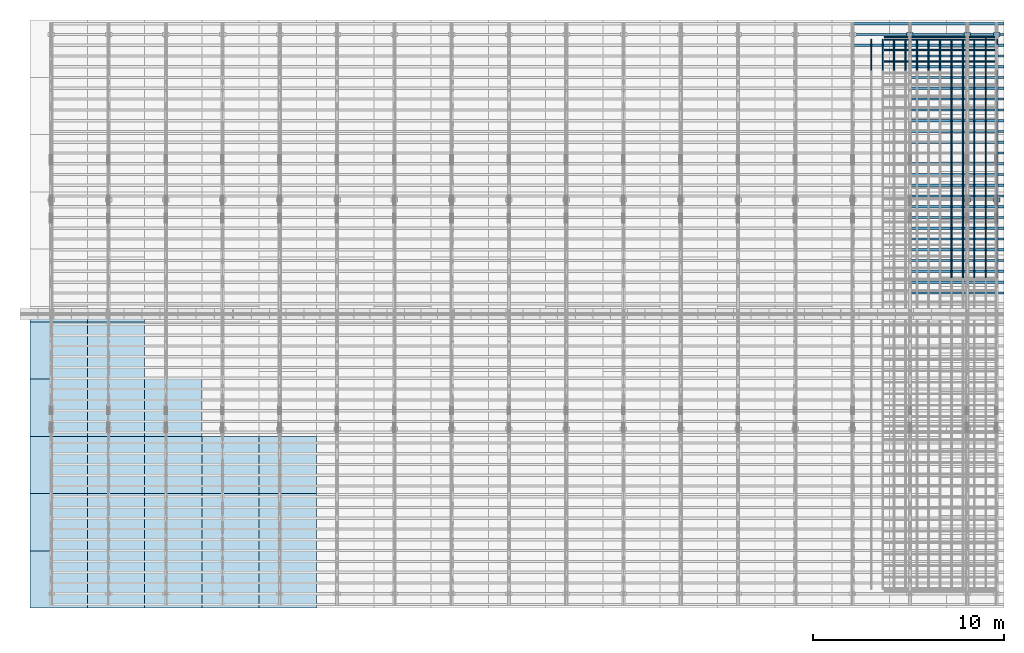
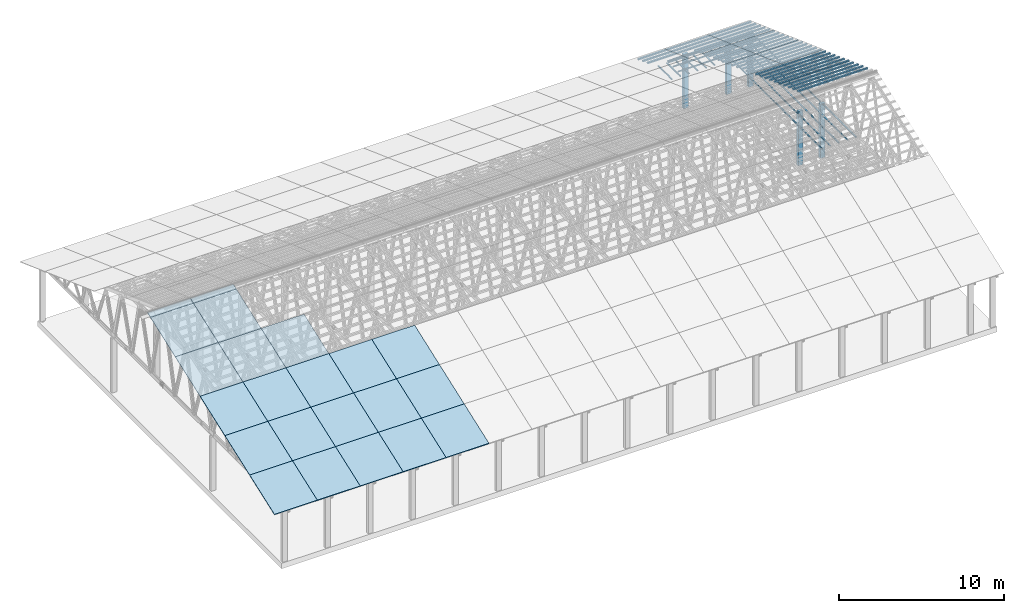
# One storey, part 5 of 189: 60 columns, 22 slabs, 22 elements without a shape of their own.
"""IFC2X3 building model written with IfcOpenShell, lengths in millimetres."""

from ifc_helpers import new_model, entity, si_unit, converted_unit, derived_unit, direction, frame, frame_2d, origin, origin_2d_with_axis, place, context, subcontext, project, spatial, rectangle, extrude, boolean, source, transform, mapped, material, layer, layer_set, type_object, type_shapes, element, aggregate, save


model = new_model("IFC2X3")

# Units and contexts
model_context = context("Model", 3, precision=0.01, world=origin(), true_north=direction((6.12303176911189e-17, 1.0)))
body_context = subcontext(model_context, "Body", "Model", "MODEL_VIEW")
ifc_project = project(units=[si_unit("LENGTHUNIT", "METRE", prefix="MILLI"), si_unit("AREAUNIT", "SQUARE_METRE"), si_unit("VOLUMEUNIT", "CUBIC_METRE"), converted_unit("PLANEANGLEUNIT", "DEGREE", entity("IfcRatioMeasure", 0.0174532925199433), si_unit("PLANEANGLEUNIT", "RADIAN"), dimensions=[0, 0, 0, 0, 0, 0, 0]), si_unit("MASSUNIT", "GRAM", prefix="KILO"), derived_unit("MASSDENSITYUNIT", [(si_unit("MASSUNIT", "GRAM", prefix="KILO"), 1), (si_unit("LENGTHUNIT", "METRE"), -3)]), si_unit("TIMEUNIT", "SECOND"), si_unit("FREQUENCYUNIT", "HERTZ"), si_unit("THERMODYNAMICTEMPERATUREUNIT", "DEGREE_CELSIUS"), derived_unit("THERMALTRANSMITTANCEUNIT", [(si_unit("MASSUNIT", "GRAM", prefix="KILO"), 1), (si_unit("THERMODYNAMICTEMPERATUREUNIT", "KELVIN"), -1), (si_unit("TIMEUNIT", "SECOND"), -3)]), derived_unit("VOLUMETRICFLOWRATEUNIT", [(si_unit("LENGTHUNIT", "METRE"), 3), (si_unit("TIMEUNIT", "SECOND"), -1)]), si_unit("ELECTRICCURRENTUNIT", "AMPERE"), si_unit("ELECTRICVOLTAGEUNIT", "VOLT"), si_unit("POWERUNIT", "WATT"), si_unit("FORCEUNIT", "NEWTON"), si_unit("ILLUMINANCEUNIT", "LUX"), si_unit("LUMINOUSFLUXUNIT", "LUMEN"), si_unit("LUMINOUSINTENSITYUNIT", "CANDELA"), derived_unit("USERDEFINED", [(si_unit("MASSUNIT", "GRAM", prefix="KILO"), -1), (si_unit("LENGTHUNIT", "METRE"), -2), (si_unit("TIMEUNIT", "SECOND"), 3), (si_unit("LUMINOUSFLUXUNIT", "LUMEN"), 1)]), derived_unit("LINEARVELOCITYUNIT", [(si_unit("LENGTHUNIT", "METRE"), 1), (si_unit("TIMEUNIT", "SECOND"), -1)]), si_unit("PRESSUREUNIT", "PASCAL"), derived_unit("USERDEFINED", [(si_unit("LENGTHUNIT", "METRE"), -2), (si_unit("MASSUNIT", "GRAM", prefix="KILO"), 1), (si_unit("TIMEUNIT", "SECOND"), -2)])], contexts=[model_context])

# Site, building, storey
site_placement = place(None, origin())
site = spatial("IfcSite", under=ifc_project, at=site_placement, CompositionType="ELEMENT")
building_placement = place(site_placement, origin())
building = spatial("IfcBuilding", under=site, at=building_placement, CompositionType="ELEMENT")
storey_placement = place(building_placement, origin())
storey = spatial("IfcBuildingStorey", under=building, at=storey_placement, Name="Default", CompositionType="ELEMENT", Elevation=0.0)

# Columns
ifc_material_1 = material(Name="2")
column_type_1 = type_object("IfcColumnType", Name="100x70", PredefinedType="COLUMN")
shared_shape_1 = source(origin(), body_context, "Body", "CSG", [
    boolean("DIFFERENCE", extrude(rectangle(XDim=4925.15713546285, YDim=117.910672112436, at=frame_2d((0.0, -7.105427357601e-15), x_axis=(1.0, 0.0))), frame((2462.57856773143, 146.833369190677, -28.6286403914047)), (0.0, 0.0, 1.0), 99.9804977897746), extrude(rectangle(XDim=70.0000000018648, YDim=100.00000000027, at=frame_2d((3.5527136788005e-15, 3.5527136788005e-15), x_axis=(0.0, 1.0))), frame((4925.15713546285, 146.833369190677, 21.3616085034827), z_axis=(1.0, 0.0, 0.0), x_axis=(0.0, 0.939692620784201, -0.34202014333036)), (0.0, 0.0, -1.0), 4925.15713546285)),
])
type_shapes(column_type_1, [shared_shape_1])
column_1_placement = place(storey_placement, frame((45228.2629498526, 29808.5761649637, 250.129187781087)))
element("IfcColumn", 1, at=column_1_placement, inside=storey, type_object=column_type_1, material=ifc_material_1, Name="H_28_35_gradi:100x70", ObjectType="H_28_35_gradi:100x70", context=body_context, shape_type="MappedRepresentation", body=[
    mapped(shared_shape_1, transform((0.0, 0.0, 0.0), scale=1.0)),
])
for number, where, name in (
    (2, (45228.2629498526, 29244.7605924922, 455.341273776488), "H_28_35_gradi:100x70"),
    (3, (45228.2629498526, 28680.9450200199, 660.553359769929), "H_28_35_gradi:100x70"),
    (4, (45228.2629498526, 28117.1294475484, 865.765445765329), "H_28_35_gradi:100x70"),
    (5, (45228.2629498526, 27553.3138750768, 1070.97753176073), "H_28_35_gradi:100x70"),
    (6, (45228.2629498526, 26989.4983026053, 1276.18961775613), "H_28_35_gradi:100x70"),
    (7, (45228.2629498526, 26425.6827301338, 1481.40170375153), "H_28_35_gradi:100x70"),
    (8, (45228.2629498526, 25861.8671576622, 1686.61378974693), "H_28_35_gradi:100x70"),
    (9, (45228.2629498526, 25298.0515851907, 1891.82587574233), "H_28_35_gradi:100x70"),
    (10, (45228.2629498526, 24734.2360127191, 2097.03796173773), "H_28_35_gradi:100x70"),
    (11, (45228.2629498526, 24170.4204402476, 2302.25004773314), "H_28_35_gradi:100x70"),
    (12, (45228.2629498526, 23606.604867776, 2507.46213372854), "H_28_35_gradi:100x70"),
    (13, (45228.2629498526, 23042.7892953045, 2712.67421972394), "H_28_35_gradi:100x70"),
    (14, (45228.2629498526, 22478.973722833, 2917.88630571934), "H_28_35_gradi:100x70"),
    (15, (45228.2629498526, 21915.1581503614, 3123.09839171474), "H_28_35_gradi:100x70"),
    (16, (45228.2629498526, 21351.3425778899, 3328.31047771014), "H_28_35_gradi:100x70"),
    (17, (45228.2629498526, 20787.5270054183, 3533.52256370554), "H_28_35_gradi:100x70"),
    (18, (45228.2629498526, 20223.7114329468, 3738.73464970094), "H_28_35_gradi:100x70"),
    (19, (45228.2629498526, 19659.8958604752, 3943.94673569634), "H_28_35_gradi:100x70"),
    (20, (45228.2629498526, 19096.0802880037, 4149.15882169174), "H_28_35_gradi:100x70"),
    (21, (45228.2629498526, 18532.2647155321, 4354.37090768715), "H_28_35_gradi:100x70"),
    (22, (45228.2629498526, 17968.4491430606, 4559.58299368255), "H_28_35_gradi:100x70"),
    (23, (45228.2629498526, 17404.633570589, 4764.79507967795), "H_28_35_gradi:100x70"),
    (24, (45228.2629498526, 16840.8179981175, 4970.00716567335), "H_28_35_gradi:100x70"),
    (25, (45228.2629498526, 16277.002425646, 5175.21925166875), "H_28_35_gradi:100x70"),
    (26, (45228.2629498526, 15713.1868531744, 5380.43133766415), "H_28_35_gradi:100x70"),
):
    element("IfcColumn", number, at=place(building_placement, frame(where)), inside=storey, type_object=column_type_1, material=ifc_material_1, Name=name, ObjectType="H_28_35_gradi:100x70", context=body_context, shape_type="MappedRepresentation", body=[
        mapped(shared_shape_1, transform((0.0, 0.0, 0.0), scale=1.0)),
    ])
column_type_2 = type_object("IfcColumnType", Name="100x70", PredefinedType="COLUMN")
shared_shape_2 = source(origin(), body_context, "Body", "CSG", [
    boolean("DIFFERENCE", extrude(rectangle(XDim=2998.26294985256, YDim=117.910672112436, at=frame_2d((0.0, -7.105427357601e-15), x_axis=(1.0, 0.0))), frame((1499.13147492628, 146.833369190677, -28.6286403914047)), (0.0, 0.0, 1.0), 99.9804977897746), extrude(rectangle(XDim=70.0000000018648, YDim=100.00000000027, at=frame_2d((3.5527136788005e-15, 3.5527136788005e-15), x_axis=(0.0, 1.0))), frame((2998.26294985256, 146.833369190677, 21.3616085034827), z_axis=(1.0, 0.0, 0.0), x_axis=(0.0, 0.939692620784201, -0.34202014333036)), (0.0, 0.0, -1.0), 2998.26294985256)),
])
type_shapes(column_type_2, [shared_shape_2])
for number, where, name in (
    (27, (42230.0, 29808.5761649637, 250.129187781087), "H_28_35_gradi:100x70"),
    (28, (42230.0, 29244.7605924922, 455.341273776488), "H_28_35_gradi:100x70"),
    (29, (42230.0, 28680.9450200199, 660.553359769929), "H_28_35_gradi:100x70"),
):
    element("IfcColumn", number, at=place(storey_placement, frame(where)), inside=storey, type_object=column_type_2, material=ifc_material_1, Name=name, ObjectType="H_28_35_gradi:100x70", context=body_context, shape_type="MappedRepresentation", body=[
        mapped(shared_shape_2, transform((0.0, 0.0, 0.0), scale=1.0)),
    ])
column_type_3 = type_object("IfcColumnType", Name="45x70", PredefinedType="COLUMN")
shared_shape_3 = source(origin(), body_context, "Body", "SweptSolid", [
    extrude(rectangle(XDim=70.0000000000007, YDim=5950.0, at=frame_2d((1.66977542903624e-13, 0.0), x_axis=(1.0, 0.0))), frame((2975.0, 237.823014276398, 0.0), z_axis=(0.0, 0.0, 1.0), x_axis=(0.0, -1.0, 0.0)), (0.0, 0.0, 1.0), 44.9999999999788),
])
type_shapes(column_type_3, [shared_shape_3])
for number, where, z_axis, x_axis, name in (
    (30, (49837.7477027694, 28217.8230142764, -45.0), (0.0, 0.0, 1.0), (-1.0, 0.0, 0.0), "H:45x70"),
    (31, (49837.7477027694, 28817.8230142764, -45.0), (0.0, 0.0, 1.0), (-1.0, 0.0, 0.0), "H:45x70"),
    (32, (49837.7477027694, 29357.8230142764, -45.0), (0.0, 0.0, 1.0), (-1.0, 0.0, 0.0), "H:45x70"),
    (33, (49837.7477027694, 29497.8230142764, -45.0), (0.0, 0.0, 1.0), (-1.0, 0.0, 0.0), "H:45x70"),
):
    element("IfcColumn", number, at=place(storey_placement, frame(where, z_axis=z_axis, x_axis=x_axis)), inside=storey, type_object=column_type_3, material=ifc_material_1, Name=name, ObjectType="H:45x70", context=body_context, shape_type="MappedRepresentation", body=[
        mapped(shared_shape_3, transform((0.0, 0.0, 0.0), scale=1.0)),
    ])
column_type_4 = type_object("IfcColumnType", Name="45x70", PredefinedType="COLUMN")
shared_shape_4 = source(origin(), body_context, "Body", "SweptSolid", [
    extrude(rectangle(XDim=70.0000000000007, YDim=5434.29684744924, at=frame_2d((1.66977542903624e-13, 0.0), x_axis=(1.0, 0.0))), frame((2717.14842372462, 237.823014276398, 0.0), z_axis=(0.0, 0.0, 1.0), x_axis=(0.0, -1.0, 0.0)), (0.0, 0.0, 1.0), 44.9999999999788),
])
type_shapes(column_type_4, [shared_shape_4])
for number, where, z_axis, x_axis, name in (
    (34, (50040.5707170458, 16647.8905423477, -90.0), (0.0, 0.0, 1.0), (0.0, 1.0, 0.0), "H:45x70"),
    (35, (49440.5707170458, 16647.8905423477, -90.0), (0.0, 0.0, 1.0), (0.0, 1.0, 0.0), "H:45x70"),
    (36, (50040.5707170459, 22082.187389797, -90.0), (0.0, 0.0, 1.0), (0.0, 1.0, 0.0), "H:45x70"),
    (37, (49440.5707170459, 22082.187389797, -90.0), (0.0, 0.0, 1.0), (0.0, 1.0, 0.0), "H:45x70"),
    (38, (48840.5707170458, 16647.8905423477, -90.0), (0.0, 0.0, 1.0), (0.0, 1.0, 0.0), "H:45x70"),
    (39, (48840.5707170459, 22082.187389797, -90.0), (0.0, 0.0, 1.0), (0.0, 1.0, 0.0), "H:45x70"),
    (40, (48240.5707170458, 16647.8905423477, -90.0), (0.0, 0.0, 1.0), (0.0, 1.0, 0.0), "H:45x70"),
    (41, (48240.5707170459, 22082.187389797, -90.0), (0.0, 0.0, 1.0), (0.0, 1.0, 0.0), "H:45x70"),
    (42, (47640.5707170458, 16647.8905423477, -90.0), (0.0, 0.0, 1.0), (0.0, 1.0, 0.0), "H:45x70"),
    (43, (47640.5707170459, 22082.187389797, -90.0), (0.0, 0.0, 1.0), (0.0, 1.0, 0.0), "H:45x70"),
):
    element("IfcColumn", number, at=place(storey_placement, frame(where, z_axis=z_axis, x_axis=x_axis)), inside=storey, type_object=column_type_4, material=ifc_material_1, Name=name, ObjectType="H:45x70", context=body_context, shape_type="MappedRepresentation", body=[
        mapped(shared_shape_4, transform((0.0, 0.0, 0.0), scale=1.0)),
    ])
column_type_5 = type_object("IfcColumnType", Name="45x70", PredefinedType="COLUMN")
shared_shape_5 = source(origin(), body_context, "Body", "SweptSolid", [
    extrude(rectangle(XDim=70.0000000000007, YDim=1638.5, at=frame_2d((1.66977542903624e-13, 0.0), x_axis=(1.0, 0.0))), frame((819.249999999999, 237.823014276398, 0.0), z_axis=(0.0, 0.0, 1.0), x_axis=(0.0, -1.0, 0.0)), (0.0, 0.0, 1.0), 44.9999999999788),
])
type_shapes(column_type_5, [shared_shape_5])
column_2_placement = place(storey_placement, frame((50040.5707170459, 27516.4842372462, -90.0), z_axis=(0.0, 0.0, 1.0), x_axis=(0.0, 1.0, 0.0)))
element("IfcColumn", 44, at=column_2_placement, inside=storey, type_object=column_type_5, material=ifc_material_1, Name="H:45x70", ObjectType="H:45x70", context=body_context, shape_type="MappedRepresentation", body=[
    mapped(shared_shape_5, transform((0.0, 0.0, 0.0), scale=1.0)),
])
column_type_6 = type_object("IfcColumnType", Name="45x70", PredefinedType="COLUMN")
shared_shape_6 = source(origin(), body_context, "Body", "SweptSolid", [
    extrude(rectangle(XDim=70.0000000000007, YDim=1778.51576275381, at=frame_2d((1.66977542903624e-13, 0.0), x_axis=(1.0, 0.0))), frame((889.257881376903, 237.823014276398, 0.0), z_axis=(0.0, 0.0, 1.0), x_axis=(0.0, -1.0, 0.0)), (0.0, 0.0, 1.0), 44.9999999999788),
])
type_shapes(column_type_6, [shared_shape_6])
column_3_placement = place(storey_placement, frame((49440.5707170459, 27516.4842372462, -90.0), z_axis=(0.0, 0.0, 1.0), x_axis=(0.0, 1.0, 0.0)))
element("IfcColumn", 45, at=column_3_placement, inside=storey, type_object=column_type_6, material=ifc_material_1, Name="H:45x70", ObjectType="H:45x70", context=body_context, shape_type="MappedRepresentation", body=[
    mapped(shared_shape_6, transform((0.0, 0.0, 0.0), scale=1.0)),
])
column_type_7 = type_object("IfcColumnType", Name="45x70", PredefinedType="COLUMN")
shared_shape_7 = source(origin(), body_context, "Body", "SweptSolid", [
    extrude(rectangle(XDim=70.0000000000007, YDim=1638.51576275384, at=frame_2d((1.66977542903624e-13, 0.0), x_axis=(1.0, 0.0))), frame((819.257881376921, 237.823014276398, 0.0), z_axis=(0.0, 0.0, 1.0), x_axis=(0.0, -1.0, 0.0)), (0.0, 0.0, 1.0), 44.9999999999788),
])
type_shapes(column_type_7, [shared_shape_7])
for number, where, z_axis, x_axis, name in (
    (46, (48840.5707170459, 27516.4842372462, -90.0), (0.0, 0.0, 1.0), (0.0, 1.0, 0.0), "H:45x70"),
    (47, (48240.5707170459, 27516.4842372462, -90.0), (0.0, 0.0, 1.0), (0.0, 1.0, 0.0), "H:45x70"),
    (48, (47640.5707170459, 27516.4842372462, -90.0), (0.0, 0.0, 1.0), (0.0, 1.0, 0.0), "H:45x70"),
    (49, (47040.5707170459, 27516.4842372462, -90.0), (0.0, 0.0, 1.0), (0.0, 1.0, 0.0), "H:45x70"),
    (50, (46440.5707170459, 27516.4842372462, -90.0), (0.0, 0.0, 1.0), (0.0, 1.0, 0.0), "H:45x70"),
    (51, (45840.5707170458, 27516.4842372462, -90.0), (0.0, 0.0, 1.0), (0.0, 1.0, 0.0), "H:45x70"),
    (52, (45240.5707170458, 27516.4842372462, -90.0), (0.0, 0.0, 1.0), (0.0, 1.0, 0.0), "H:45x70"),
    (53, (44640.5707170458, 27516.4842372462, -90.0), (0.0, 0.0, 1.0), (0.0, 1.0, 0.0), "H:45x70"),
    (54, (44040.5707170458, 27516.4842372462, -90.0), (0.0, 0.0, 1.0), (0.0, 1.0, 0.0), "H:45x70"),
    (55, (43440.5707170458, 27516.4842372462, -90.0), (0.0, 0.0, 1.0), (0.0, 1.0, 0.0), "H:45x70"),
):
    element("IfcColumn", number, at=place(storey_placement, frame(where, z_axis=z_axis, x_axis=x_axis)), inside=storey, type_object=column_type_7, material=ifc_material_1, Name=name, ObjectType="H:45x70", context=body_context, shape_type="MappedRepresentation", body=[
        mapped(shared_shape_7, transform((0.0, 0.0, 0.0), scale=1.0)),
    ])
ifc_material_2 = material()
column_type_8 = type_object("IfcColumnType", Name="200x200", PredefinedType="COLUMN")
shared_shape_8 = source(origin(), body_context, "Body", "SweptSolid", [
    extrude(rectangle(XDim=339.999999999998, YDim=200.000000000004, at=origin_2d_with_axis()), frame((100.0, 280.0, -4000.0), z_axis=(0.0, 0.0, 1.0), x_axis=(0.0, -1.0, 0.0)), (0.0, 0.0, 1.0), 4000.0),
])
type_shapes(column_type_8, [shared_shape_8])
for number, where, z_axis, x_axis, name in (
    (56, (50050.0, 20629.6217832149, 0.0), (0.0, 0.0, 1.0), (0.0, 1.0, 0.0), "V:200x200"),
    (57, (48510.0, 20629.6217832149, 0.0), (0.0, 0.0, 1.0), (0.0, 1.0, 0.0), "V:200x200"),
    (58, (48510.0, 29300.0, 0.0), (0.0, 0.0, 1.0), (0.0, 1.0, 0.0), "V:200x200"),
    (59, (50050.0, 29300.0, 0.0), (0.0, 0.0, 1.0), (0.0, 1.0, 0.0), "V:200x200"),
    (60, (45510.0, 29300.0, 0.0), (0.0, 0.0, 1.0), (0.0, 1.0, 0.0), "V:200x200"),
):
    element("IfcColumn", number, at=place(storey_placement, frame(where, z_axis=z_axis, x_axis=x_axis)), inside=storey, type_object=column_type_8, material=ifc_material_2, Name=name, ObjectType="V:200x200", context=body_context, shape_type="MappedRepresentation", body=[
        mapped(shared_shape_8, transform((0.0, 0.0, 0.0), scale=1.0)),
    ])

# Roof, slab
roof_1_placement = place(storey_placement, frame((11153.4200853157, -652.222549250722, 238.115215731819)))
roof_1 = element("IfcRoof", 61, at=roof_1_placement, inside=storey, ShapeType="NOTDEFINED")
ifc_material_3 = material()
ifc_layer = layer(ifc_material_3, 40.0)
ifc_layer_set = layer_set([ifc_layer])
slab_1_placement = place(roof_1_placement, origin())
slab_1 = element("IfcSlab", 62, at=slab_1_placement, material=ifc_layer_set, PredefinedType="ROOF", context=body_context, shape_type="SweptSolid", body=[
    extrude(rectangle(XDim=3192.53331742773, YDim=2999.99999999999, at=frame_2d((0.0, -3.41060513164848e-13), x_axis=(0.0, -1.0))), frame((1500.0, 1500.0, 545.955351399302), z_axis=(0.0, -0.342020143325668, 0.939692620785909), x_axis=(1.0, 0.0, 0.0)), (0.0, 0.342020143325668, 0.939692620785909), 42.5671108990364),
])
aggregate(roof_1, [slab_1])

roof_2_placement = place(storey_placement, frame((11153.4200853157, 2347.77745074928, 1330.02591853042)))
roof_2 = element("IfcRoof", 63, at=roof_2_placement, inside=storey, ShapeType="NOTDEFINED")
slab_2_placement = place(roof_2_placement, origin())
slab_2 = element("IfcSlab", 64, at=slab_2_placement, material=ifc_layer_set, PredefinedType="ROOF", context=body_context, shape_type="SweptSolid", body=[
    extrude(rectangle(XDim=3192.53331742773, YDim=2999.99999999999, at=frame_2d((0.0, -1.13686837721616e-13), x_axis=(0.0, -1.0))), frame((1500.0, 1500.0, 545.955351399302), z_axis=(0.0, -0.342020143325668, 0.939692620785909), x_axis=(1.0, 0.0, 0.0)), (0.0, 0.342020143325668, 0.939692620785909), 42.5671108990353),
])
aggregate(roof_2, [slab_2])

roof_3_placement = place(storey_placement, frame((11153.4200853157, 5347.77745074928, 2421.93662132902)))
roof_3 = element("IfcRoof", 65, at=roof_3_placement, inside=storey, ShapeType="NOTDEFINED")
slab_3_placement = place(roof_3_placement, origin())
slab_3 = element("IfcSlab", 66, at=slab_3_placement, material=ifc_layer_set, PredefinedType="ROOF", context=body_context, shape_type="SweptSolid", body=[
    extrude(rectangle(XDim=3192.53331742773, YDim=2999.99999999999, at=frame_2d((0.0, 0.0), x_axis=(0.0, -1.0))), frame((1500.0, 1500.0, 545.955351399302), z_axis=(0.0, -0.342020143325668, 0.939692620785909), x_axis=(1.0, 0.0, 0.0)), (0.0, 0.342020143325668, 0.939692620785909), 42.5671108990355),
])
aggregate(roof_3, [slab_3])

roof_4_placement = place(storey_placement, frame((8153.42008531574, -652.222549250713, 238.115215731819)))
roof_4 = element("IfcRoof", 67, at=roof_4_placement, inside=storey, ShapeType="NOTDEFINED")
slab_4_placement = place(roof_4_placement, origin())
slab_4 = element("IfcSlab", 68, at=slab_4_placement, material=ifc_layer_set, PredefinedType="ROOF", context=body_context, shape_type="SweptSolid", body=[
    extrude(rectangle(XDim=3192.53331742773, YDim=2999.99999999999, at=frame_2d((0.0, -3.41060513164848e-13), x_axis=(0.0, -1.0))), frame((1500.0, 1500.0, 545.955351399302), z_axis=(0.0, -0.342020143325668, 0.939692620785909), x_axis=(1.0, 0.0, 0.0)), (0.0, 0.342020143325668, 0.939692620785909), 42.5671108990364),
])
aggregate(roof_4, [slab_4])

roof_5_placement = place(storey_placement, frame((8153.42008531577, 2347.77745074929, 1330.02591853042)))
roof_5 = element("IfcRoof", 69, at=roof_5_placement, inside=storey, ShapeType="NOTDEFINED")
slab_5_placement = place(roof_5_placement, origin())
slab_5 = element("IfcSlab", 70, at=slab_5_placement, material=ifc_layer_set, PredefinedType="ROOF", context=body_context, shape_type="SweptSolid", body=[
    extrude(rectangle(XDim=3192.53331742773, YDim=2999.99999999999, at=frame_2d((0.0, -1.13686837721616e-13), x_axis=(0.0, -1.0))), frame((1500.0, 1500.0, 545.955351399302), z_axis=(0.0, -0.342020143325668, 0.939692620785909), x_axis=(1.0, 0.0, 0.0)), (0.0, 0.342020143325668, 0.939692620785909), 42.5671108990353),
])
aggregate(roof_5, [slab_5])

roof_6_placement = place(storey_placement, frame((8153.42008531577, 5347.77745074929, 2421.93662132902)))
roof_6 = element("IfcRoof", 71, at=roof_6_placement, inside=storey, ShapeType="NOTDEFINED")
slab_6_placement = place(roof_6_placement, origin())
slab_6 = element("IfcSlab", 72, at=slab_6_placement, material=ifc_layer_set, PredefinedType="ROOF", context=body_context, shape_type="SweptSolid", body=[
    extrude(rectangle(XDim=3192.53331742773, YDim=2999.99999999999, at=frame_2d((0.0, 0.0), x_axis=(0.0, -1.0))), frame((1500.0, 1500.0, 545.955351399302), z_axis=(0.0, -0.342020143325668, 0.939692620785909), x_axis=(1.0, 0.0, 0.0)), (0.0, 0.342020143325668, 0.939692620785909), 42.5671108990355),
])
aggregate(roof_6, [slab_6])

roof_7_placement = place(storey_placement, frame((5153.42008531576, -652.222549250704, 238.115215731819)))
roof_7 = element("IfcRoof", 73, at=roof_7_placement, inside=storey, ShapeType="NOTDEFINED")
slab_7_placement = place(roof_7_placement, origin())
slab_7 = element("IfcSlab", 74, at=slab_7_placement, material=ifc_layer_set, PredefinedType="ROOF", context=body_context, shape_type="SweptSolid", body=[
    extrude(rectangle(XDim=3192.53331742773, YDim=2999.99999999999, at=frame_2d((0.0, -3.41060513164848e-13), x_axis=(0.0, -1.0))), frame((1500.0, 1500.0, 545.955351399302), z_axis=(0.0, -0.342020143325668, 0.939692620785909), x_axis=(1.0, 0.0, 0.0)), (0.0, 0.342020143325668, 0.939692620785909), 42.5671108990364),
])
aggregate(roof_7, [slab_7])

roof_8_placement = place(storey_placement, frame((5153.42008531579, 2347.77745074929, 1330.02591853042)))
roof_8 = element("IfcRoof", 75, at=roof_8_placement, inside=storey, ShapeType="NOTDEFINED")
slab_8_placement = place(roof_8_placement, origin())
slab_8 = element("IfcSlab", 76, at=slab_8_placement, material=ifc_layer_set, PredefinedType="ROOF", context=body_context, shape_type="SweptSolid", body=[
    extrude(rectangle(XDim=3192.53331742773, YDim=2999.99999999999, at=frame_2d((0.0, -1.13686837721616e-13), x_axis=(0.0, -1.0))), frame((1500.0, 1500.0, 545.955351399302), z_axis=(0.0, -0.342020143325668, 0.939692620785909), x_axis=(1.0, 0.0, 0.0)), (0.0, 0.342020143325668, 0.939692620785909), 42.5671108990353),
])
aggregate(roof_8, [slab_8])

roof_9_placement = place(storey_placement, frame((5153.42008531579, 5347.7774507493, 2421.93662132902)))
roof_9 = element("IfcRoof", 77, at=roof_9_placement, inside=storey, ShapeType="NOTDEFINED")
slab_9_placement = place(roof_9_placement, origin())
slab_9 = element("IfcSlab", 78, at=slab_9_placement, material=ifc_layer_set, PredefinedType="ROOF", context=body_context, shape_type="SweptSolid", body=[
    extrude(rectangle(XDim=3192.53331742773, YDim=2999.99999999999, at=frame_2d((0.0, 0.0), x_axis=(0.0, -1.0))), frame((1500.0, 1500.0, 545.955351399302), z_axis=(0.0, -0.342020143325668, 0.939692620785909), x_axis=(1.0, 0.0, 0.0)), (0.0, 0.342020143325668, 0.939692620785909), 42.5671108990355),
])
aggregate(roof_9, [slab_9])

roof_10_placement = place(storey_placement, frame((5153.42008531579, 8347.7774507493, 3513.84732412761)))
roof_10 = element("IfcRoof", 79, at=roof_10_placement, inside=storey, ShapeType="NOTDEFINED")
slab_10_placement = place(roof_10_placement, origin())
slab_10 = element("IfcSlab", 80, at=slab_10_placement, material=ifc_layer_set, PredefinedType="ROOF", context=body_context, shape_type="SweptSolid", body=[
    extrude(rectangle(XDim=3192.53331742773, YDim=2999.99999999999, at=frame_2d((0.0, 0.0), x_axis=(0.0, -1.0))), frame((1500.0, 1500.0, 545.955351399301), z_axis=(0.0, -0.342020143325668, 0.939692620785909), x_axis=(1.0, 0.0, 0.0)), (0.0, 0.342020143325668, 0.939692620785909), 42.5671108990366),
])
aggregate(roof_10, [slab_10])

roof_11_placement = place(storey_placement, frame((2153.42008531578, -652.222549250695, 238.115215731819)))
roof_11 = element("IfcRoof", 81, at=roof_11_placement, inside=storey, ShapeType="NOTDEFINED")
slab_11_placement = place(roof_11_placement, origin())
slab_11 = element("IfcSlab", 82, at=slab_11_placement, material=ifc_layer_set, PredefinedType="ROOF", context=body_context, shape_type="SweptSolid", body=[
    extrude(rectangle(XDim=3192.53331742773, YDim=2999.99999999999, at=frame_2d((0.0, -3.41060513164848e-13), x_axis=(0.0, -1.0))), frame((1500.0, 1500.0, 545.955351399302), z_axis=(0.0, -0.342020143325668, 0.939692620785909), x_axis=(1.0, 0.0, 0.0)), (0.0, 0.342020143325668, 0.939692620785909), 42.5671108990364),
])
aggregate(roof_11, [slab_11])

roof_12_placement = place(storey_placement, frame((2153.42008531582, 2347.7774507493, 1330.02591853042)))
roof_12 = element("IfcRoof", 83, at=roof_12_placement, inside=storey, ShapeType="NOTDEFINED")
slab_12_placement = place(roof_12_placement, origin())
slab_12 = element("IfcSlab", 84, at=slab_12_placement, material=ifc_layer_set, PredefinedType="ROOF", context=body_context, shape_type="SweptSolid", body=[
    extrude(rectangle(XDim=3192.53331742773, YDim=2999.99999999999, at=frame_2d((0.0, -1.13686837721616e-13), x_axis=(0.0, -1.0))), frame((1500.0, 1500.0, 545.955351399302), z_axis=(0.0, -0.342020143325668, 0.939692620785909), x_axis=(1.0, 0.0, 0.0)), (0.0, 0.342020143325668, 0.939692620785909), 42.5671108990353),
])
aggregate(roof_12, [slab_12])

roof_13_placement = place(storey_placement, frame((2153.42008531582, 5347.77745074931, 2421.93662132902)))
roof_13 = element("IfcRoof", 85, at=roof_13_placement, inside=storey, ShapeType="NOTDEFINED")
slab_13_placement = place(roof_13_placement, origin())
slab_13 = element("IfcSlab", 86, at=slab_13_placement, material=ifc_layer_set, PredefinedType="ROOF", context=body_context, shape_type="SweptSolid", body=[
    extrude(rectangle(XDim=3192.53331742773, YDim=2999.99999999999, at=frame_2d((0.0, 0.0), x_axis=(0.0, -1.0))), frame((1500.0, 1500.0, 545.955351399302), z_axis=(0.0, -0.342020143325668, 0.939692620785909), x_axis=(1.0, 0.0, 0.0)), (0.0, 0.342020143325668, 0.939692620785909), 42.5671108990355),
])
aggregate(roof_13, [slab_13])

roof_14_placement = place(storey_placement, frame((2153.42008531582, 8347.77745074931, 3513.84732412761)))
roof_14 = element("IfcRoof", 87, at=roof_14_placement, inside=storey, ShapeType="NOTDEFINED")
slab_14_placement = place(roof_14_placement, origin())
slab_14 = element("IfcSlab", 88, at=slab_14_placement, material=ifc_layer_set, PredefinedType="ROOF", context=body_context, shape_type="SweptSolid", body=[
    extrude(rectangle(XDim=3192.53331742773, YDim=2999.99999999999, at=frame_2d((0.0, 0.0), x_axis=(0.0, -1.0))), frame((1500.0, 1500.0, 545.955351399301), z_axis=(0.0, -0.342020143325668, 0.939692620785909), x_axis=(1.0, 0.0, 0.0)), (0.0, 0.342020143325668, 0.939692620785909), 42.5671108990366),
])
aggregate(roof_14, [slab_14])

roof_15_placement = place(storey_placement, frame((2153.42008531582, 11347.7774507493, 4605.75802692621)))
roof_15 = element("IfcRoof", 89, at=roof_15_placement, inside=storey, ShapeType="NOTDEFINED")
slab_15_placement = place(roof_15_placement, origin())
slab_15 = element("IfcSlab", 90, at=slab_15_placement, material=ifc_layer_set, PredefinedType="ROOF", context=body_context, shape_type="SweptSolid", body=[
    extrude(rectangle(XDim=3192.53331742773, YDim=2999.99999999999, at=frame_2d((0.0, 0.0), x_axis=(0.0, -1.0))), frame((1500.0, 1500.0, 545.955351399303), z_axis=(0.0, -0.342020143325669, 0.939692620785908), x_axis=(1.0, 0.0, 0.0)), (0.0, 0.342020143325669, 0.939692620785908), 42.5671108990361),
])
aggregate(roof_15, [slab_15])

roof_16_placement = place(storey_placement, frame((2153.42008531582, 11750.0000438632, 4752.15507836903)))
roof_16 = element("IfcRoof", 91, at=roof_16_placement, inside=storey, ShapeType="NOTDEFINED")
slab_16_placement = place(roof_16_placement, origin())
slab_16 = element("IfcSlab", 92, at=slab_16_placement, material=ifc_layer_set, PredefinedType="ROOF", context=body_context, shape_type="SweptSolid", body=[
    extrude(rectangle(XDim=3192.53331742773, YDim=2999.99999999999, at=frame_2d((0.0, 0.0), x_axis=(0.0, -1.0))), frame((1500.0, 1500.0, 545.955351399303), z_axis=(0.0, -0.342020143325669, 0.939692620785908), x_axis=(1.0, 0.0, 0.0)), (0.0, 0.342020143325669, 0.939692620785908), 42.5671108990361),
])
aggregate(roof_16, [slab_16])

roof_17_placement = place(storey_placement, frame((-846.579914684194, -652.222549250687, 238.115215731819)))
roof_17 = element("IfcRoof", 93, at=roof_17_placement, inside=storey, ShapeType="NOTDEFINED")
slab_17_placement = place(roof_17_placement, origin())
slab_17 = element("IfcSlab", 94, at=slab_17_placement, material=ifc_layer_set, PredefinedType="ROOF", context=body_context, shape_type="SweptSolid", body=[
    extrude(rectangle(XDim=3192.53331742773, YDim=2999.99999999999, at=frame_2d((0.0, -3.41060513164848e-13), x_axis=(0.0, -1.0))), frame((1500.0, 1500.0, 545.955351399302), z_axis=(0.0, -0.342020143325668, 0.939692620785909), x_axis=(1.0, 0.0, 0.0)), (0.0, 0.342020143325668, 0.939692620785909), 42.5671108990364),
])
aggregate(roof_17, [slab_17])

roof_18_placement = place(storey_placement, frame((-846.579914684159, 2347.77745074931, 1330.02591853042)))
roof_18 = element("IfcRoof", 95, at=roof_18_placement, inside=storey, ShapeType="NOTDEFINED")
slab_18_placement = place(roof_18_placement, origin())
slab_18 = element("IfcSlab", 96, at=slab_18_placement, material=ifc_layer_set, PredefinedType="ROOF", context=body_context, shape_type="SweptSolid", body=[
    extrude(rectangle(XDim=3192.53331742773, YDim=2999.99999999999, at=frame_2d((0.0, -1.13686837721616e-13), x_axis=(0.0, -1.0))), frame((1500.0, 1500.0, 545.955351399302), z_axis=(0.0, -0.342020143325668, 0.939692620785909), x_axis=(1.0, 0.0, 0.0)), (0.0, 0.342020143325668, 0.939692620785909), 42.5671108990353),
])
aggregate(roof_18, [slab_18])

roof_19_placement = place(storey_placement, frame((-846.579914684159, 5347.77745074931, 2421.93662132902)))
roof_19 = element("IfcRoof", 97, at=roof_19_placement, inside=storey, ShapeType="NOTDEFINED")
slab_19_placement = place(roof_19_placement, origin())
slab_19 = element("IfcSlab", 98, at=slab_19_placement, material=ifc_layer_set, PredefinedType="ROOF", context=body_context, shape_type="SweptSolid", body=[
    extrude(rectangle(XDim=3192.53331742773, YDim=2999.99999999999, at=frame_2d((0.0, 0.0), x_axis=(0.0, -1.0))), frame((1500.0, 1500.0, 545.955351399302), z_axis=(0.0, -0.342020143325668, 0.939692620785909), x_axis=(1.0, 0.0, 0.0)), (0.0, 0.342020143325668, 0.939692620785909), 42.5671108990355),
])
aggregate(roof_19, [slab_19])

roof_20_placement = place(storey_placement, frame((-846.579914684159, 8347.77745074932, 3513.84732412761)))
roof_20 = element("IfcRoof", 99, at=roof_20_placement, inside=storey, ShapeType="NOTDEFINED")
slab_20_placement = place(roof_20_placement, origin())
slab_20 = element("IfcSlab", 100, at=slab_20_placement, material=ifc_layer_set, PredefinedType="ROOF", context=body_context, shape_type="SweptSolid", body=[
    extrude(rectangle(XDim=3192.53331742773, YDim=2999.99999999999, at=frame_2d((0.0, 0.0), x_axis=(0.0, -1.0))), frame((1500.0, 1500.0, 545.955351399301), z_axis=(0.0, -0.342020143325668, 0.939692620785909), x_axis=(1.0, 0.0, 0.0)), (0.0, 0.342020143325668, 0.939692620785909), 42.5671108990366),
])
aggregate(roof_20, [slab_20])

roof_21_placement = place(storey_placement, frame((-846.579914684159, 11347.7774507493, 4605.75802692621)))
roof_21 = element("IfcRoof", 101, at=roof_21_placement, inside=storey, ShapeType="NOTDEFINED")
slab_21_placement = place(roof_21_placement, origin())
slab_21 = element("IfcSlab", 102, at=slab_21_placement, material=ifc_layer_set, PredefinedType="ROOF", context=body_context, shape_type="SweptSolid", body=[
    extrude(rectangle(XDim=3192.53331742773, YDim=2999.99999999999, at=frame_2d((0.0, 0.0), x_axis=(0.0, -1.0))), frame((1500.0, 1500.0, 545.955351399303), z_axis=(0.0, -0.342020143325669, 0.939692620785908), x_axis=(1.0, 0.0, 0.0)), (0.0, 0.342020143325669, 0.939692620785908), 42.5671108990361),
])
aggregate(roof_21, [slab_21])

roof_22_placement = place(storey_placement, frame((-846.579914684159, 11750.0000438632, 4752.15507836903)))
roof_22 = element("IfcRoof", 103, at=roof_22_placement, inside=storey, ShapeType="NOTDEFINED")
slab_22_placement = place(roof_22_placement, origin())
slab_22 = element("IfcSlab", 104, at=slab_22_placement, material=ifc_layer_set, PredefinedType="ROOF", context=body_context, shape_type="SweptSolid", body=[
    extrude(rectangle(XDim=3192.53331742773, YDim=2999.99999999999, at=frame_2d((0.0, 0.0), x_axis=(0.0, -1.0))), frame((1500.0, 1500.0, 545.955351399303), z_axis=(0.0, -0.342020143325669, 0.939692620785908), x_axis=(1.0, 0.0, 0.0)), (0.0, 0.342020143325669, 0.939692620785908), 42.5671108990361),
])
aggregate(roof_22, [slab_22])

save(model, "model.ifc")
